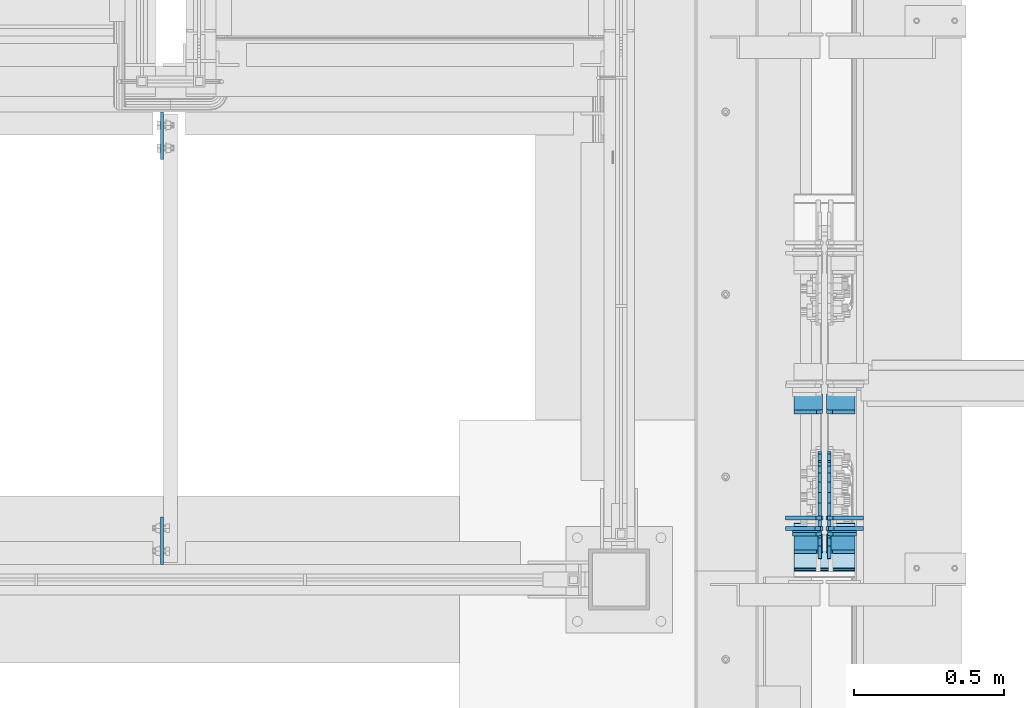
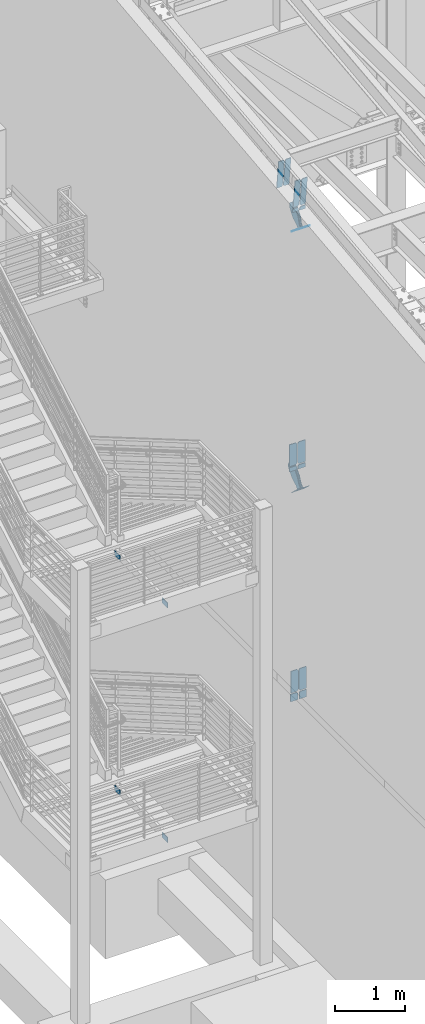
# One storey, part 1023 of 1179: 24 plates, 13 elements without a shape of their own.
"""IFC2X3 building model written with IfcOpenShell, lengths in millimetres."""

import ifcopenshell
import ifcopenshell.guid

model = None  # the IFC model being written
_history = None  # IfcOwnerHistory: only IFC2X3 demands one
_inside = {}  # id of a spatial element -> (the spatial element, [elements in it])
_under = {}  # id of a project, library or spatial element -> (it, [spatial elements below it])
_declared = {}  # id of a project -> (the project, [libraries it declares])
_typed = {}  # id of a type object -> (the type object, [elements of that type])
_made_of = {}  # id of a material, layer set ... -> (it, [elements and type objects made of it])


def new_model(schema):
    """Start an empty IFC model of exactly this schema.

    Asked for "IFC4X3", IfcOpenShell would pick the latest addendum, in which some entities
    have other attributes; the version numbers below select the first issue.
    IFC2X3 requires an IfcOwnerHistory on every rooted entity: one is made here for all.
    """
    global model, _history
    if schema == "IFC4X3":
        model = ifcopenshell.file(schema_version=(4, 3, 0, 0))
    else:
        model = ifcopenshell.file(schema=schema)
    _inside.clear()
    _under.clear()
    _declared.clear()
    _typed.clear()
    _made_of.clear()
    _history = None
    if model.schema == "IFC2X3":
        org = make("IfcOrganization", Name="unknown")
        user = make(
            "IfcPersonAndOrganization",
            ThePerson=make("IfcPerson", FamilyName="unknown"),
            TheOrganization=org,
        )
        app = make(
            "IfcApplication",
            ApplicationDeveloper=org,
            Version="unknown",
            ApplicationFullName="unknown",
            ApplicationIdentifier="unknown",
        )
        _history = make(
            "IfcOwnerHistory",
            OwningUser=user,
            OwningApplication=app,
            ChangeAction="ADDED",
            CreationDate=0,
        )
    return model


def make(cls, **values):
    """One entity of the class cls with the attributes given. An attribute that is None is left unset."""
    return model.create_entity(
        cls, **{name: value for name, value in values.items() if value is not None}
    )


def rooted(cls, **values):
    """An entity with a GlobalId (a new one), such as an element, a storey or a relation."""
    return make(cls, GlobalId=ifcopenshell.guid.new(), OwnerHistory=_history, **values)


def si_unit(unit_type, name, prefix=None):
    """IfcSIUnit, for example si_unit("LENGTHUNIT", "METRE", prefix="MILLI")."""
    return make("IfcSIUnit", UnitType=unit_type, Prefix=prefix, Name=name)


def assignment(units):
    """IfcUnitAssignment: the units of a project."""
    return None if units is None else make("IfcUnitAssignment", Units=units)


def point(xyz):
    """IfcCartesianPoint."""
    return None if xyz is None else make("IfcCartesianPoint", Coordinates=xyz)


def direction(xyz):
    """IfcDirection."""
    return None if xyz is None else make("IfcDirection", DirectionRatios=xyz)


def frame(location, z_axis=None, x_axis=None):
    """IfcAxis2Placement3D, a coordinate frame: its origin and axes. An axis left out is left unset."""
    return make(
        "IfcAxis2Placement3D",
        Location=point(location),
        Axis=direction(z_axis),
        RefDirection=direction(x_axis),
    )


def origin_with_axes():
    """The frame at (0, 0, 0) with the z axis (0, 0, 1) and the x axis (1, 0, 0) written out."""
    return frame((0.0, 0.0, 0.0), z_axis=(0.0, 0.0, 1.0), x_axis=(1.0, 0.0, 0.0))


def place(relative_to, where):
    """IfcLocalPlacement: puts the frame where relative to a parent placement (None: the world)."""
    return make(
        "IfcLocalPlacement", PlacementRelTo=relative_to, RelativePlacement=where
    )


def context(
    kind, dimensions, precision=None, world=None, true_north=None, identifier=None
):
    """IfcGeometricRepresentationContext, for example the 3D "Model" context."""
    return make(
        "IfcGeometricRepresentationContext",
        ContextIdentifier=identifier,
        ContextType=kind,
        CoordinateSpaceDimension=dimensions,
        Precision=precision,
        WorldCoordinateSystem=world,
        TrueNorth=true_north,
    )


def subcontext(parent, identifier, kind, view, scale=None):
    """IfcGeometricRepresentationSubContext, for example "Body" below "Model"."""
    return make(
        "IfcGeometricRepresentationSubContext",
        ContextIdentifier=identifier,
        ContextType=kind,
        ParentContext=parent,
        TargetScale=scale,
        TargetView=view,
    )


def project(units=None, contexts=None):
    """IfcProject with its units and contexts."""
    return rooted(
        "IfcProject",
        Name="project",
        RepresentationContexts=contexts,
        UnitsInContext=assignment(units),
    )


def spatial(cls, under=None, at=None, **own):
    """A site, building, storey or space (cls), placed at a placement, below another one or the project."""
    s = rooted(cls, ObjectPlacement=at, **own)
    if under is not None:
        _under.setdefault(under.id(), (under, []))[1].append(s)
    return s


def faces_of(points, faces, orient=None, outer=None):
    """IfcFace entities. A face is a list of loops; a loop is a list of indices into points, from 0.

    orient and outer hold one flag for each loop. By default every Orientation is true, the
    first loop of a face is its IfcFaceOuterBound and the others are IfcFaceBound.
    """
    made = []
    for i, loops in enumerate(faces):
        bounds = []
        for j, loop in enumerate(loops):
            is_outer = j == 0 if outer is None else outer[i][j]
            bounds.append(
                make(
                    "IfcFaceOuterBound" if is_outer else "IfcFaceBound",
                    Bound=make("IfcPolyLoop", Polygon=[points[k] for k in loop]),
                    Orientation=True if orient is None else orient[i][j],
                )
            )
        made.append(make("IfcFace", Bounds=bounds))
    return made


def faceted_brep(points, faces, orient=None, outer=None, voids=None):
    """IfcFacetedBrep: a solid bounded by flat faces; with voids (closed shells), ...WithVoids."""
    shared = [point(p) for p in points]
    hull = make("IfcClosedShell", CfsFaces=faces_of(shared, faces, orient, outer))
    if voids is None:
        return make("IfcFacetedBrep", Outer=hull)
    return make(
        "IfcFacetedBrepWithVoids",
        Outer=hull,
        Voids=[
            make(cls, CfsFaces=faces_of(shared, fs, o, b)) for cls, fs, o, b in voids
        ],
    )


def shape(context_of_items, identifier, shape_type, items):
    """IfcShapeRepresentation: the items that make up one representation, for example the "Body"."""
    return make(
        "IfcShapeRepresentation",
        ContextOfItems=context_of_items,
        RepresentationIdentifier=identifier,
        RepresentationType=shape_type,
        Items=items,
    )


def material(Name=None, Category=None):
    """IfcMaterial."""
    return make("IfcMaterial", Name=Name, Category=Category)


def made_of(thing, what):
    """Note that an element or type object is made of a material, layer set ...; save() writes the relation."""
    if what is not None:
        _made_of.setdefault(what.id(), (what, []))[1].append(thing)
    return thing


def type_object(cls, material=None, **own):
    """A type object (cls), such as IfcWallType, which elements share."""
    return made_of(rooted(cls, **own), material)


def element(
    cls,
    number,
    at=None,
    inside=None,
    cuts=None,
    type_object=None,
    material=None,
    context=None,
    identifier="Body",
    shape_type=None,
    held_by="IfcProductDefinitionShape",
    body=None,
    shapes=None,
    **own,
):
    """One element of the class cls, such as IfcWall. Its Tag is "e" and its number.

    at: its placement. inside: the storey or other place that contains it. cuts: it is an
    opening in that element (IfcRelVoidsElement). A single representation is given by context,
    identifier, shape_type and body (its items); several are given by shapes. held_by: the class
    of the entity that holds the representations. save() writes the other relations.
    """
    e = rooted(cls, Tag="e%d" % number, ObjectPlacement=at, **own)
    if body is not None:
        shapes = [shape(context, identifier, shape_type, body)]
    if shapes is not None:
        e.Representation = make(held_by, Representations=shapes)
    if inside is not None:
        _inside.setdefault(inside.id(), (inside, []))[1].append(e)
    if cuts is not None:
        rooted(
            "IfcRelVoidsElement", RelatingBuildingElement=cuts, RelatedOpeningElement=e
        )
    if type_object is not None:
        _typed.setdefault(type_object.id(), (type_object, []))[1].append(e)
    return made_of(e, material)


def aggregate(whole, parts):
    """IfcRelAggregates: a whole, such as a stair, and the parts it consists of."""
    return rooted("IfcRelAggregates", RelatingObject=whole, RelatedObjects=parts)


def save(model, path):
    """Write the relations noted so far, then the file.

    IfcRelAggregates (storeys below a building ...), IfcRelContainedInSpatialStructure (elements
    in a storey), IfcRelDefinesByType, IfcRelAssociatesMaterial and IfcRelDeclares: one each for
    every whole, place, type object, material and project.
    """
    for whole, parts in _under.values():
        aggregate(whole, parts)
    for where, things in _inside.values():
        rooted(
            "IfcRelContainedInSpatialStructure",
            RelatedElements=things,
            RelatingStructure=where,
        )
    for kind, things in _typed.values():
        rooted("IfcRelDefinesByType", RelatedObjects=things, RelatingType=kind)
    for what, things in _made_of.values():
        rooted("IfcRelAssociatesMaterial", RelatedObjects=things, RelatingMaterial=what)
    for by, libraries in _declared.values():
        rooted("IfcRelDeclares", RelatingContext=by, RelatedDefinitions=libraries)
    model.write(path)


model = new_model("IFC2X3")

# Units and contexts
model_context = context("Model", 3, precision=1e-05, world=origin_with_axes())
body_context = subcontext(model_context, "Body", "Model", "MODEL_VIEW")
ifc_project = project(units=[si_unit("LENGTHUNIT", "METRE", prefix="MILLI"), si_unit("AREAUNIT", "SQUARE_METRE"), si_unit("VOLUMEUNIT", "CUBIC_METRE"), si_unit("MASSUNIT", "GRAM", prefix="KILO"), si_unit("TIMEUNIT", "SECOND"), si_unit("PLANEANGLEUNIT", "RADIAN"), si_unit("SOLIDANGLEUNIT", "STERADIAN"), si_unit("THERMODYNAMICTEMPERATUREUNIT", "DEGREE_CELSIUS"), si_unit("LUMINOUSINTENSITYUNIT", "LUMEN")], contexts=[model_context])

# Site, building, storey
site_placement = place(None, origin_with_axes())
site = spatial("IfcSite", under=ifc_project, at=site_placement, CompositionType="ELEMENT")
building_placement = place(site_placement, origin_with_axes())
building = spatial("IfcBuilding", under=site, at=building_placement, Name="Undefined", CompositionType="ELEMENT")
storey_placement = place(building_placement, origin_with_axes())
storey = spatial("IfcBuildingStorey", under=building, at=storey_placement, Name="Undefined", CompositionType="ELEMENT", Elevation=0.0)

# Assembly, plate
assembly_1_placement = place(storey_placement, origin_with_axes())
assembly_1 = element("IfcElementAssembly", 1, at=assembly_1_placement, inside=storey, Name="BEAM", AssemblyPlace="NOTDEFINED", PredefinedType="RIGID_FRAME")
ifc_material_1 = material(Name="STEEL/A36")
plate_type_1 = type_object("IfcPlateType", PredefinedType="NOTDEFINED")
plate_1_placement = place(assembly_1_placement, frame((-1781.175, 31635.7, 1997.075), z_axis=(0.0, -1.0, 0.0), x_axis=(0.0, 0.0, -1.0)))
plate_1 = element("IfcPlate", 2, at=plate_1_placement, type_object=plate_type_1, material=ifc_material_1, Name="PLATE", context=body_context, shape_type="Brep", body=[
    faceted_brep([(0.0, -4.76249999999709, 0.0), (0.0, -4.76250000000005, 158.75), (0.0, 4.76250000000005, 158.75), (0.0, 4.76249999999709, 0.0), (88.8999999999996, -4.76250000000005, 158.75), (88.8999999999996, 4.76250000000005, 158.75), (88.8999999999996, -4.76250000000005, 0.0), (88.8999999999996, 4.76250000000005, 0.0)], [[[0, 1, 2, 3]], [[1, 4, 5, 2]], [[4, 6, 7, 5]], [[6, 0, 3, 7]], [[5, 7, 3, 2]], [[6, 4, 1, 0]]]),
])
aggregate(assembly_1, [plate_1])

assembly_2_placement = place(storey_placement, origin_with_axes())
assembly_2 = element("IfcElementAssembly", 3, at=assembly_2_placement, inside=storey, Name="BEAM", AssemblyPlace="NOTDEFINED", PredefinedType="RIGID_FRAME")
plate_2_placement = place(assembly_2_placement, frame((-1781.175, 31635.7, 6070.6), z_axis=(0.0, -1.0, 0.0), x_axis=(0.0, 0.0, -1.0)))
plate_2 = element("IfcPlate", 4, at=plate_2_placement, type_object=plate_type_1, material=ifc_material_1, Name="PLATE", context=body_context, shape_type="Brep", body=[
    faceted_brep([(0.0, -4.76249999999709, 0.0), (0.0, -4.76250000000005, 158.75), (0.0, 4.76250000000005, 158.75), (0.0, 4.76249999999709, 0.0), (88.8999999999996, -4.76250000000005, 158.75), (88.8999999999996, 4.76250000000005, 158.75), (88.8999999999996, -4.76250000000005, 0.0), (88.8999999999996, 4.76250000000005, 0.0)], [[[0, 1, 2, 3]], [[1, 4, 5, 2]], [[4, 6, 7, 5]], [[6, 0, 3, 7]], [[5, 7, 3, 2]], [[6, 4, 1, 0]]]),
])
aggregate(assembly_2, [plate_2])

assembly_3_placement = place(storey_placement, origin_with_axes())
assembly_3 = element("IfcElementAssembly", 5, at=assembly_3_placement, inside=storey, Name="BEAM", AssemblyPlace="NOTDEFINED", PredefinedType="RIGID_FRAME")
plate_3_placement = place(assembly_3_placement, frame((-1781.175, 30124.4, 6070.6), z_axis=(0.0, 1.0, 0.0), x_axis=(0.0, 0.0, -1.0)))
plate_3 = element("IfcPlate", 6, at=plate_3_placement, type_object=plate_type_1, material=ifc_material_1, Name="PLATE", context=body_context, shape_type="Brep", body=[
    faceted_brep([(0.0, -4.76249999999709, 0.0), (0.0, -4.76250000000005, 158.75), (0.0, 4.76250000000005, 158.75), (0.0, 4.76249999999709, 0.0), (88.8999999999996, -4.76250000000005, 158.75), (88.8999999999996, 4.76250000000005, 158.75), (88.8999999999996, -4.76250000000005, 0.0), (88.8999999999996, 4.76250000000005, 0.0)], [[[0, 1, 2, 3]], [[1, 4, 5, 2]], [[4, 6, 7, 5]], [[6, 0, 3, 7]], [[5, 7, 3, 2]], [[6, 4, 1, 0]]]),
])
aggregate(assembly_3, [plate_3])

assembly_4_placement = place(storey_placement, origin_with_axes())
assembly_4 = element("IfcElementAssembly", 7, at=assembly_4_placement, inside=storey, Name="BEAM", AssemblyPlace="NOTDEFINED", PredefinedType="RIGID_FRAME")
plate_4_placement = place(assembly_4_placement, frame((-1781.175, 30124.4, 1997.075), z_axis=(0.0, 1.0, 0.0), x_axis=(0.0, 0.0, -1.0)))
plate_4 = element("IfcPlate", 8, at=plate_4_placement, type_object=plate_type_1, material=ifc_material_1, Name="PLATE", context=body_context, shape_type="Brep", body=[
    faceted_brep([(0.0, -4.76249999999709, 0.0), (0.0, -4.76250000000005, 158.75), (0.0, 4.76250000000005, 158.75), (0.0, 4.76249999999709, 0.0), (88.8999999999996, -4.76250000000005, 158.75), (88.8999999999996, 4.76250000000005, 158.75), (88.8999999999996, -4.76250000000005, 0.0), (88.8999999999996, 4.76250000000005, 0.0)], [[[0, 1, 2, 3]], [[1, 4, 5, 2]], [[4, 6, 7, 5]], [[6, 0, 3, 7]], [[5, 7, 3, 2]], [[6, 4, 1, 0]]]),
])
aggregate(assembly_4, [plate_4])

# Assembly, plates
assembly_5_placement = place(storey_placement, origin_with_axes())
assembly_5 = element("IfcElementAssembly", 9, at=assembly_5_placement, inside=storey, Name="BEAM", AssemblyPlace="NOTDEFINED", PredefinedType="RIGID_FRAME")
ifc_material_2 = material(Name="STEEL/A572-GR.50")
plate_type_2 = type_object("IfcPlateType", PredefinedType="NOTDEFINED")
plate_5_placement = place(assembly_5_placement, frame((534.193750000002, 30689.0189603065, 12187.4895843678), z_axis=(0.0, -0.112284087038017, 0.993676146336441), x_axis=(-1.0, 0.0, 0.0)))
plate_5 = element("IfcPlate", 10, at=plate_5_placement, type_object=plate_type_2, material=ifc_material_2, Name="PLATE", context=body_context, shape_type="Brep", body=[
    faceted_brep([(0.0, -6.34999999999854, 0.0), (0.0, -6.35000000019863, 498.474999998592), (0.0, 6.34999999979118, 498.474999998596), (0.0, 6.34999999999854, 0.0), (76.2000007629395, -6.35000000019863, 498.474999998592), (76.2000007629395, 6.34999999979118, 498.474999998596), (95.25, -6.350000000195, 479.425000761541), (95.25, 6.34999999980209, 479.425000761548), (95.25, -6.35000000000946, 19.0499992370496), (95.25, 6.34999999998399, 19.0499992370533), (76.2000007629395, -6.35000000000218, 0.0), (76.2000007629395, 6.34999999999491, 3.63797880709171e-12)], [[[0, 1, 2, 3]], [[1, 4, 5, 2]], [[4, 6, 7, 5]], [[6, 8, 9, 7]], [[8, 10, 11, 9]], [[10, 0, 3, 11]], [[5, 7, 9, 11, 3, 2]], [[10, 8, 6, 4, 1, 0]]]),
])
plate_6_placement = place(assembly_5_placement, frame((424.656250000002, 30689.0189603065, 12187.4895843678), z_axis=(0.0, -0.112284087038017, 0.993676146336441), x_axis=(-1.0, 0.0, 0.0)))
plate_6 = element("IfcPlate", 11, at=plate_6_placement, type_object=plate_type_2, material=ifc_material_2, Name="PLATE", context=body_context, shape_type="Brep", body=[
    faceted_brep([(0.0, -6.35000000000036, 19.0499999999993), (0.0, -6.350000000195, 479.425000761541), (0.0, 6.34999999980209, 479.425000761548), (0.0, 6.35000000000036, 19.0499999999993), (19.0499992370605, -6.35000000019863, 498.474999998592), (19.0499992370605, 6.34999999979118, 498.474999998596), (95.25, -6.349999999793, 498.474999998598), (95.25, 6.35000000020045, 498.474999998592), (95.25, -6.34999999999309, 1.81898940354586e-12), (95.25, 6.34999999999854, -1.81898940354586e-12), (19.0500000000002, -6.35000000000036, 0.0), (19.0500000000002, 6.35000000000036, 0.0)], [[[0, 1, 2, 3]], [[1, 4, 5, 2]], [[4, 6, 7, 5]], [[6, 8, 9, 7]], [[8, 10, 11, 9]], [[3, 11, 10, 0]], [[5, 7, 9, 11, 3, 2]], [[10, 8, 6, 4, 1, 0]]]),
])
plate_7_placement = place(assembly_5_placement, frame((534.193750000002, 30222.4134704941, 12134.7637826834), z_axis=(0.0, -0.112284087038017, 0.993676146336441), x_axis=(-1.0, 0.0, 0.0)))
plate_7 = element("IfcPlate", 12, at=plate_7_placement, type_object=plate_type_2, material=ifc_material_2, Name="PLATE", context=body_context, shape_type="Brep", body=[
    faceted_brep([(0.0, -6.34999999999854, 0.0), (0.0, -6.35000000019863, 498.474999998592), (0.0, 6.34999999979118, 498.474999998596), (0.0, 6.34999999999854, 0.0), (76.2000007629395, -6.35000000019863, 498.474999998592), (76.2000007629395, 6.34999999979118, 498.474999998596), (95.25, -6.350000000195, 479.425000761541), (95.25, 6.34999999980209, 479.425000761548), (95.25, -6.35000000000946, 19.0499992370496), (95.25, 6.34999999998399, 19.0499992370533), (76.2000007629395, -6.35000000000218, 0.0), (76.2000007629395, 6.34999999999491, 3.63797880709171e-12)], [[[0, 1, 2, 3]], [[1, 4, 5, 2]], [[4, 6, 7, 5]], [[6, 8, 9, 7]], [[8, 10, 11, 9]], [[10, 0, 3, 11]], [[5, 7, 9, 11, 3, 2]], [[10, 8, 6, 4, 1, 0]]]),
])
plate_8_placement = place(assembly_5_placement, frame((424.656250000002, 30222.4134704941, 12134.7637826834), z_axis=(0.0, -0.112284087038017, 0.993676146336441), x_axis=(-1.0, 0.0, 0.0)))
plate_8 = element("IfcPlate", 13, at=plate_8_placement, type_object=plate_type_2, material=ifc_material_2, Name="PLATE", context=body_context, shape_type="Brep", body=[
    faceted_brep([(0.0, -6.35000000000036, 19.0499999999993), (0.0, -6.350000000195, 479.425000761541), (0.0, 6.34999999980209, 479.425000761548), (0.0, 6.35000000000036, 19.0499999999993), (19.0499992370605, -6.35000000019863, 498.474999998592), (19.0499992370605, 6.34999999979118, 498.474999998596), (95.25, -6.349999999793, 498.474999998598), (95.25, 6.35000000020045, 498.474999998592), (95.25, -6.34999999999309, 1.81898940354586e-12), (95.25, 6.34999999999854, -1.81898940354586e-12), (19.0500000000002, -6.35000000000036, 0.0), (19.0500000000002, 6.35000000000036, 0.0)], [[[0, 1, 2, 3]], [[1, 4, 5, 2]], [[4, 6, 7, 5]], [[6, 8, 9, 7]], [[8, 10, 11, 9]], [[3, 11, 10, 0]], [[5, 7, 9, 11, 3, 2]], [[10, 8, 6, 4, 1, 0]]]),
])

assembly_6_placement = place(storey_placement, origin_with_axes())
assembly_6 = element("IfcElementAssembly", 14, at=assembly_6_placement, inside=storey, Name="BEAM", AssemblyPlace="NOTDEFINED", PredefinedType="RIGID_FRAME")
plate_type_3 = type_object("IfcPlateType", PredefinedType="NOTDEFINED")
plate_9_placement = place(assembly_6_placement, frame((558.006250000002, 30244.1470435544, 3703.6375), z_axis=(0.0, 0.0, 1.0), x_axis=(-1.0, 0.0, 0.0)))
plate_9 = element("IfcPlate", 15, at=plate_9_placement, type_object=plate_type_3, material=ifc_material_2, Name="PLATE", context=body_context, shape_type="Brep", body=[
    faceted_brep([(0.0, -6.34999999999854, 0.0), (0.0, -6.35000000000036, 377.825012207031), (0.0, 6.35000000000036, 377.825012207031), (0.0, 6.34999999999854, 0.0), (98.4250011444092, -6.35000000000036, 377.825012207031), (98.4250011444092, 6.35000000000036, 377.825012207031), (120.650001525879, -6.35000000000036, 355.600011825562), (120.650001525879, 6.35000000000036, 355.600011825562), (120.650001525879, -6.35000000000036, 22.2250003814697), (120.650001525879, 6.35000000000036, 22.2250003814697), (98.4250011444092, -6.35000000000036, 0.0), (98.4250011444092, 6.35000000000036, 0.0)], [[[0, 1, 2, 3]], [[1, 4, 5, 2]], [[4, 6, 7, 5]], [[6, 8, 9, 7]], [[8, 10, 11, 9]], [[10, 0, 3, 11]], [[5, 7, 9, 11, 3, 2]], [[10, 8, 6, 4, 1, 0]]]),
])
plate_10_placement = place(assembly_6_placement, frame((426.243750000002, 30244.1470435544, 3703.6375), z_axis=(0.0, 0.0, 1.0), x_axis=(-1.0, 0.0, 0.0)))
plate_10 = element("IfcPlate", 16, at=plate_10_placement, type_object=plate_type_3, material=ifc_material_2, Name="PLATE", context=body_context, shape_type="Brep", body=[
    faceted_brep([(0.0, -6.34999999999854, 22.2250003814697), (0.0, -6.34999999999854, 355.600011825562), (0.0, 6.34999999999854, 355.600011825562), (0.0, 6.34999999999854, 22.2250003814697), (22.2250003814697, -6.34999999999854, 377.825012207031), (22.2250003814697, 6.34999999999854, 377.825012207031), (120.650001525879, -6.34999999999854, 377.825012207031), (120.650001525879, 6.34999999999854, 377.825012207031), (120.650001525879, -6.34999999999854, 0.0), (120.650001525879, 6.34999999999854, 0.0), (22.2250003814697, -6.34999999999854, 0.0), (22.2250003814697, 6.34999999999854, 0.0)], [[[0, 1, 2, 3]], [[1, 4, 5, 2]], [[4, 6, 7, 5]], [[6, 8, 9, 7]], [[8, 10, 11, 9]], [[10, 0, 3, 11]], [[5, 7, 9, 11, 3, 2]], [[10, 8, 6, 4, 1, 0]]]),
])

# Assembly, plate
assembly_7_placement = place(storey_placement, origin_with_axes())
assembly_7 = element("IfcElementAssembly", 17, at=assembly_7_placement, inside=storey, AssemblyPlace="NOTDEFINED", PredefinedType="RIGID_FRAME")
plate_type_4 = type_object("IfcPlateType", PredefinedType="NOTDEFINED")
plate_11_placement = place(assembly_7_placement, frame((415.925000000002, 30215.3602857066, 11728.8505438446), z_axis=(0.0, -0.784152810390106, 0.620567780308725), x_axis=(0.0, 0.620567780308726, 0.784152810390106)))
plate_11 = element("IfcPlate", 18, at=plate_11_placement, type_object=plate_type_4, material=ifc_material_1, context=body_context, shape_type="Brep", body=[
    faceted_brep([(0.0, -6.34999999999854, 0.0), (-8.18545231595635e-11, -6.34999999999854, 91.5986124346418), (-8.18545231595635e-11, 6.34999999999854, 91.5986124346418), (0.0, 6.34999999999854, 0.0), (67.3100000000013, -6.35000000000002, 91.5986124352912), (67.3100000000013, 6.35000000000002, 91.5986124352912), (168.909999999782, -6.35000000000002, 136.286806218), (168.909999999782, 6.35000000000002, 136.286806218), (313.994985846162, -6.35000000000002, 136.286806217971), (313.994985846162, 6.35000000000002, 136.286806217971), (348.623054100175, -6.35000000000002, 129.398855183776), (348.623054100175, 6.35000000000002, 129.398855183776), (377.979312866712, -6.35000000000002, 109.783630186734), (377.979312866712, 6.35000000000002, 109.783630186734), (397.594537863708, -6.35000000000002, 80.4273714201881), (397.594537863708, 6.35000000000002, 80.4273714201881), (404.482488897822, -6.35000000000002, 45.7993092687429), (404.482488897822, 6.35000000000002, 45.7993092687429), (397.594537863562, -6.35000000000002, 11.1712410148175), (397.594537863562, 6.35000000000002, 11.1712410148175), (377.979312866471, -6.35000000000002, -18.1850177516571), (377.979312866471, 6.35000000000002, -18.1850177516571), (348.623054099906, -6.35000000000002, -37.800242748639), (348.623054099906, 6.35000000000002, -37.800242748639), (313.994988897899, -6.35000000000002, -44.6881937828002), (313.994988897899, 6.35000000000002, -44.6881937828002), (168.909999999352, -6.35000000000002, -44.6881937827711), (168.909999999352, 6.35000000000002, -44.6881937827711), (67.309999999783, -6.35000000000002, -1.09139364212751e-11), (67.309999999783, 6.35000000000002, -1.09139364212751e-11)], [[[0, 1, 2, 3]], [[1, 4, 5, 2]], [[4, 6, 7, 5]], [[6, 8, 9, 7]], [[8, 10, 11, 9]], [[10, 12, 13, 11]], [[12, 14, 15, 13]], [[14, 16, 17, 15]], [[16, 18, 19, 17]], [[18, 20, 21, 19]], [[20, 22, 23, 21]], [[22, 24, 25, 23]], [[24, 26, 27, 25]], [[26, 28, 29, 27]], [[28, 0, 3, 29]], [[5, 7, 9, 11, 13, 15, 17, 19, 21, 23, 25, 27, 29, 3, 2]], [[28, 26, 24, 22, 20, 18, 16, 14, 12, 10, 8, 6, 4, 1, 0]]]),
])
aggregate(assembly_7, [plate_11])

assembly_8_placement = place(storey_placement, origin_with_axes())
assembly_8 = element("IfcElementAssembly", 19, at=assembly_8_placement, inside=storey, AssemblyPlace="NOTDEFINED", PredefinedType="RIGID_FRAME")
plate_12_placement = place(assembly_8_placement, frame((447.675000000002, 30215.3602857066, 11728.8505438446), z_axis=(0.0, -0.784152810390106, 0.620567780308725), x_axis=(0.0, 0.620567780308726, 0.784152810390106)))
plate_12 = element("IfcPlate", 20, at=plate_12_placement, type_object=plate_type_4, material=ifc_material_1, context=body_context, shape_type="Brep", body=[
    faceted_brep([(0.0, -6.34999999999854, 0.0), (-8.18545231595635e-11, -6.34999999999854, 91.5986124346418), (-8.18545231595635e-11, 6.34999999999854, 91.5986124346418), (0.0, 6.34999999999854, 0.0), (67.3100000000013, -6.35000000000002, 91.5986124352912), (67.3100000000013, 6.35000000000002, 91.5986124352912), (168.909999999782, -6.35000000000002, 136.286806218), (168.909999999782, 6.35000000000002, 136.286806218), (313.994985846162, -6.35000000000002, 136.286806217971), (313.994985846162, 6.35000000000002, 136.286806217971), (348.623054100175, -6.35000000000002, 129.398855183776), (348.623054100175, 6.35000000000002, 129.398855183776), (377.979312866712, -6.35000000000002, 109.783630186734), (377.979312866712, 6.35000000000002, 109.783630186734), (397.594537863708, -6.35000000000002, 80.4273714201881), (397.594537863708, 6.35000000000002, 80.4273714201881), (404.482488897822, -6.35000000000002, 45.7993092687429), (404.482488897822, 6.35000000000002, 45.7993092687429), (397.594537863562, -6.35000000000002, 11.1712410148175), (397.594537863562, 6.35000000000002, 11.1712410148175), (377.979312866471, -6.35000000000002, -18.1850177516571), (377.979312866471, 6.35000000000002, -18.1850177516571), (348.623054099906, -6.35000000000002, -37.800242748639), (348.623054099906, 6.35000000000002, -37.800242748639), (313.994988897899, -6.35000000000002, -44.6881937828002), (313.994988897899, 6.35000000000002, -44.6881937828002), (168.909999999352, -6.35000000000002, -44.6881937827711), (168.909999999352, 6.35000000000002, -44.6881937827711), (67.309999999783, -6.35000000000002, -1.09139364212751e-11), (67.309999999783, 6.35000000000002, -1.09139364212751e-11)], [[[0, 1, 2, 3]], [[1, 4, 5, 2]], [[4, 6, 7, 5]], [[6, 8, 9, 7]], [[8, 10, 11, 9]], [[10, 12, 13, 11]], [[12, 14, 15, 13]], [[14, 16, 17, 15]], [[16, 18, 19, 17]], [[18, 20, 21, 19]], [[20, 22, 23, 21]], [[22, 24, 25, 23]], [[24, 26, 27, 25]], [[26, 28, 29, 27]], [[28, 0, 3, 29]], [[5, 7, 9, 11, 13, 15, 17, 19, 21, 23, 25, 27, 29, 3, 2]], [[28, 26, 24, 22, 20, 18, 16, 14, 12, 10, 8, 6, 4, 1, 0]]]),
])
aggregate(assembly_8, [plate_12])

assembly_9_placement = place(storey_placement, origin_with_axes())
assembly_9 = element("IfcElementAssembly", 21, at=assembly_9_placement, inside=storey, Name="Plate", AssemblyPlace="NOTDEFINED", PredefinedType="RIGID_FRAME")
plate_type_5 = type_object("IfcPlateType", PredefinedType="NOTDEFINED")
plate_13_placement = place(assembly_9_placement, frame((533.400000000002, 30261.0868592656, 11696.7121163379), z_axis=(0.0, -0.784152810390106, 0.620567780308725), x_axis=(-1.0, 0.0, 0.0)))
plate_13 = element("IfcPlate", 22, at=plate_13_placement, type_object=plate_type_5, material=ifc_material_1, Name="Plate", context=body_context, shape_type="Brep", body=[
    faceted_brep([(0.0, -3.17500000000109, 0.0), (0.0, -3.17500000000291, 203.200000000368), (0.0, 3.17499999998836, 203.200000000361), (0.0, 3.17500000000109, 7.27595761418343e-12), (203.199999999997, -3.17500000000291, 203.200000000368), (203.199999999997, 3.17499999998836, 203.200000000361), (203.199999999997, -3.17499999999927, 3.63797880709171e-12), (203.199999999997, 3.17499999999382, -3.63797880709171e-12)], [[[0, 1, 2, 3]], [[1, 4, 5, 2]], [[4, 6, 7, 5]], [[6, 0, 3, 7]], [[5, 7, 3, 2]], [[6, 4, 1, 0]]]),
])
aggregate(assembly_9, [plate_13])

assembly_10_placement = place(storey_placement, origin_with_axes())
assembly_10 = element("IfcElementAssembly", 23, at=assembly_10_placement, inside=storey, Name="Plate", AssemblyPlace="NOTDEFINED", PredefinedType="RIGID_FRAME")
plate_14_placement = place(assembly_10_placement, frame((533.400000000002, 30258.8835102338, 7162.85000806995), z_axis=(0.0, -0.729241792887682, 0.684256097894611), x_axis=(-1.0, 0.0, 0.0)))
plate_14 = element("IfcPlate", 24, at=plate_14_placement, type_object=plate_type_5, material=ifc_material_1, Name="Plate", context=body_context, shape_type="Brep", body=[
    faceted_brep([(0.0, -3.17500000000109, 0.0), (0.0, -3.17500000000291, 203.200000000368), (0.0, 3.17499999998836, 203.200000000361), (0.0, 3.17500000000109, 7.27595761418343e-12), (203.199999999997, -3.17500000000291, 203.200000000368), (203.199999999997, 3.17499999998836, 203.200000000361), (203.199999999997, -3.17499999999927, 3.63797880709171e-12), (203.199999999997, 3.17499999999382, -3.63797880709171e-12)], [[[0, 1, 2, 3]], [[1, 4, 5, 2]], [[4, 6, 7, 5]], [[6, 0, 3, 7]], [[5, 7, 3, 2]], [[6, 4, 1, 0]]]),
])
aggregate(assembly_10, [plate_14])

# Plate
plate_type_6 = type_object("IfcPlateType", PredefinedType="NOTDEFINED")
plate_15_placement = place(assembly_5_placement, frame((422.275000000001, 30224.9425551523, 12109.4879184263), z_axis=(-1.0, 0.0, 0.0), x_axis=(0.0, 0.112284087038014, -0.993676146336441)))
plate_15 = element("IfcPlate", 25, at=plate_15_placement, type_object=plate_type_6, material=ifc_material_2, Name="PLATE", context=body_context, shape_type="Brep", body=[
    faceted_brep([(0.0, 6.35000000000036, 19.0499999999993), (19.0500000000002, 6.35000000000036, 0.0), (19.0500000000002, -6.35000000000036, 0.0), (0.0, -6.35000000000036, 19.0499999999993), (0.0, -6.35000000000036, 96.8374999999978), (0.0, 6.35000000000036, 96.8374999999978), (67.1710410456399, -6.34999999997308, 96.8375), (67.1710410456326, 6.35000000002037, 96.8375), (67.1710410456399, -6.34999999997308, 0.0), (67.1710410456326, 6.35000000002037, 0.0)], [[[0, 1, 2, 3]], [[4, 5, 0, 3]], [[4, 6, 7, 5]], [[6, 8, 9, 7]], [[9, 8, 2, 1]], [[5, 7, 9, 1, 0]], [[8, 6, 4, 3, 2]]]),
])

plate_16_placement = place(assembly_5_placement, frame((441.325000000001, 30224.9425551523, 12109.4879184263), z_axis=(1.0, 0.0, 0.0), x_axis=(0.0, 0.112284087038014, -0.993676146336441)))
plate_16 = element("IfcPlate", 26, at=plate_16_placement, type_object=plate_type_6, material=ifc_material_2, Name="PLATE", context=body_context, shape_type="Brep", body=[
    faceted_brep([(0.0, 6.35000000000036, 19.0499999999993), (19.0500000000002, 6.35000000000036, 0.0), (19.0500000000002, -6.35000000000036, 0.0), (0.0, -6.35000000000036, 19.0499999999993), (0.0, -6.35000000000036, 96.8374999999978), (0.0, 6.35000000000036, 96.8374999999978), (67.1710410456399, -6.34999999997308, 96.8375), (67.1710410456326, 6.35000000002037, 96.8375), (67.1710410456399, -6.34999999997308, 0.0), (67.1710410456326, 6.35000000002037, 0.0)], [[[0, 1, 2, 3]], [[4, 5, 0, 3]], [[4, 6, 7, 5]], [[6, 8, 9, 7]], [[9, 8, 2, 1]], [[5, 7, 9, 1, 0]], [[8, 6, 4, 3, 2]]]),
])

aggregate(assembly_5, [plate_5, plate_6, plate_7, plate_8, plate_15, plate_16])

# Assembly, plates
assembly_11_placement = place(storey_placement, origin_with_axes())
assembly_11 = element("IfcElementAssembly", 27, at=assembly_11_placement, inside=storey, Name="BEAM", AssemblyPlace="NOTDEFINED", PredefinedType="RIGID_FRAME")
plate_type_7 = type_object("IfcPlateType", PredefinedType="NOTDEFINED")
plate_17_placement = place(assembly_11_placement, frame((422.275, 30278.9504404273, 7594.6), z_axis=(-1.0, 0.0, 0.0), x_axis=(0.0, 0.0, -1.0)))
plate_17 = element("IfcPlate", 28, at=plate_17_placement, type_object=plate_type_7, material=ifc_material_2, Name="PLATE", context=body_context, shape_type="Brep", body=[
    faceted_brep([(0.0, 6.35000000000036, 19.0499999999993), (19.0500000000002, 6.35000000000036, 0.0), (19.0500000000002, -6.35000000000036, 0.0), (0.0, -6.35000000000036, 19.0499999999993), (0.0, -6.34999999999854, 120.650000000001), (0.0, 6.34999999999854, 120.650000000001), (72.5857973213488, -6.34999999999854, 120.65), (72.5857973213488, 6.34999999999854, 120.65), (72.5857973213488, -6.34999999999854, 0.0), (72.5857973213488, 6.34999999999854, 0.0)], [[[0, 1, 2, 3]], [[4, 5, 0, 3]], [[4, 6, 7, 5]], [[6, 8, 9, 7]], [[9, 8, 2, 1]], [[5, 7, 9, 1, 0]], [[8, 6, 4, 3, 2]]]),
])
plate_18_placement = place(assembly_11_placement, frame((441.325, 30278.9504404273, 7594.6), z_axis=(1.0, 0.0, 0.0), x_axis=(0.0, 0.0, -1.0)))
plate_18 = element("IfcPlate", 29, at=plate_18_placement, type_object=plate_type_7, material=ifc_material_2, Name="PLATE", context=body_context, shape_type="Brep", body=[
    faceted_brep([(0.0, 6.35000000000036, 19.0499999999993), (19.0500000000002, 6.35000000000036, 0.0), (19.0500000000002, -6.35000000000036, 0.0), (0.0, -6.35000000000036, 19.0499999999993), (0.0, -6.34999999999854, 120.650000000001), (0.0, 6.34999999999854, 120.650000000001), (72.5857973213488, -6.34999999999854, 120.65), (72.5857973213488, 6.34999999999854, 120.65), (72.5857973213488, -6.34999999999854, 0.0), (72.5857973213488, 6.34999999999854, 0.0)], [[[0, 1, 2, 3]], [[4, 5, 0, 3]], [[4, 6, 7, 5]], [[6, 8, 9, 7]], [[9, 8, 2, 1]], [[5, 7, 9, 1, 0]], [[8, 6, 4, 3, 2]]]),
])
plate_type_8 = type_object("IfcPlateType", PredefinedType="NOTDEFINED")
plate_19_placement = place(assembly_11_placement, frame((426.243750000001, 30278.9504404273, 7615.2375), z_axis=(-1.0, 0.0, 0.0), x_axis=(0.0, 0.0, 1.0)))
plate_19 = element("IfcPlate", 30, at=plate_19_placement, type_object=plate_type_8, material=ifc_material_2, Name="PLATE", context=body_context, shape_type="Brep", body=[
    faceted_brep([(0.0, -6.34999999999854, 22.2250003814697), (0.0, -6.34999999999854, 124.618750000001), (0.0, 6.34999999999854, 124.618750000001), (0.0, 6.34999999999854, 22.2250003814697), (377.825000000001, -6.34999999999854, 124.61875), (377.825000000001, 6.34999999999854, 124.61875), (377.825000000001, -6.34999999999854, 22.2250003814697), (377.825000000001, 6.34999999999854, 22.2250003814697), (355.599999618531, -6.34999999999854, 0.0), (355.599999618531, 6.34999999999854, 0.0), (22.2250003814697, -6.34999999999854, 0.0), (22.2250003814697, 6.34999999999854, 0.0)], [[[0, 1, 2, 3]], [[1, 4, 5, 2]], [[4, 6, 7, 5]], [[6, 8, 9, 7]], [[8, 10, 11, 9]], [[10, 0, 3, 11]], [[5, 7, 9, 11, 3, 2]], [[10, 8, 6, 4, 1, 0]]]),
])
plate_20_placement = place(assembly_11_placement, frame((437.356250000001, 30278.9504404273, 7615.2375), z_axis=(1.0, 0.0, 0.0), x_axis=(0.0, 0.0, 1.0)))
plate_20 = element("IfcPlate", 31, at=plate_20_placement, type_object=plate_type_8, material=ifc_material_2, Name="PLATE", context=body_context, shape_type="Brep", body=[
    faceted_brep([(0.0, -6.34999999999854, 22.2250003814697), (0.0, -6.34999999999854, 124.618750000001), (0.0, 6.34999999999854, 124.618750000001), (0.0, 6.34999999999854, 22.2250003814697), (377.825000000001, -6.34999999999854, 124.61875), (377.825000000001, 6.34999999999854, 124.61875), (377.825000000001, -6.34999999999854, 22.2250003814697), (377.825000000001, 6.34999999999854, 22.2250003814697), (355.599999618531, -6.34999999999854, 0.0), (355.599999618531, 6.34999999999854, 0.0), (22.2250003814697, -6.34999999999854, 0.0), (22.2250003814697, 6.34999999999854, 0.0)], [[[0, 1, 2, 3]], [[1, 4, 5, 2]], [[4, 6, 7, 5]], [[6, 8, 9, 7]], [[8, 10, 11, 9]], [[10, 0, 3, 11]], [[5, 7, 9, 11, 3, 2]], [[10, 8, 6, 4, 1, 0]]]),
])
aggregate(assembly_11, [plate_17, plate_18, plate_19, plate_20])

# Plate
plate_type_9 = type_object("IfcPlateType", PredefinedType="NOTDEFINED")
plate_21_placement = place(assembly_6_placement, frame((419.100000000001, 30244.146981566, 3683.00000010165), z_axis=(-1.0, 0.0, 0.0), x_axis=(0.0, 0.0, -1.0)))
plate_21 = element("IfcPlate", 32, at=plate_21_placement, type_object=plate_type_9, material=ifc_material_2, Name="PLATE", context=body_context, shape_type="Brep", body=[
    faceted_brep([(0.0, -6.35000000000036, 19.0499999999993), (0.0, -6.35000000000036, 117.474999999999), (0.0, 6.35000000000036, 117.474999999999), (0.0, 6.35000000000036, 19.0499999999993), (131.240777340528, -6.34999999982756, 117.475), (131.240777340528, 6.35000000017317, 117.475), (131.240777340528, -6.34999999982756, 0.0), (131.240777340528, 6.35000000017317, 0.0), (19.0500000000002, -6.35000000000036, 0.0), (19.0500000000002, 6.35000000000036, 0.0)], [[[0, 1, 2, 3]], [[1, 4, 5, 2]], [[4, 6, 7, 5]], [[6, 8, 9, 7]], [[3, 9, 8, 0]], [[5, 7, 9, 3, 2]], [[8, 6, 4, 1, 0]]]),
])

plate_22_placement = place(assembly_6_placement, frame((444.500000000001, 30244.146981566, 3683.00000010165), z_axis=(1.0, 0.0, 0.0), x_axis=(0.0, 0.0, -1.0)))
plate_22 = element("IfcPlate", 33, at=plate_22_placement, type_object=plate_type_9, material=ifc_material_2, Name="PLATE", context=body_context, shape_type="Brep", body=[
    faceted_brep([(0.0, -6.35000000000036, 19.0499999999993), (0.0, -6.35000000000036, 117.474999999999), (0.0, 6.35000000000036, 117.474999999999), (0.0, 6.35000000000036, 19.0499999999993), (131.240777340528, -6.34999999982756, 117.475), (131.240777340528, 6.35000000017317, 117.475), (131.240777340528, -6.34999999982756, 0.0), (131.240777340528, 6.35000000017317, 0.0), (19.0500000000002, -6.35000000000036, 0.0), (19.0500000000002, 6.35000000000036, 0.0)], [[[0, 1, 2, 3]], [[1, 4, 5, 2]], [[4, 6, 7, 5]], [[6, 8, 9, 7]], [[3, 9, 8, 0]], [[5, 7, 9, 3, 2]], [[8, 6, 4, 1, 0]]]),
])

aggregate(assembly_6, [plate_21, plate_22, plate_9, plate_10])

# Assembly, plate
assembly_12_placement = place(storey_placement, origin_with_axes())
assembly_12 = element("IfcElementAssembly", 34, at=assembly_12_placement, inside=storey, AssemblyPlace="NOTDEFINED", PredefinedType="RIGID_FRAME")
plate_type_10 = type_object("IfcPlateType", PredefinedType="NOTDEFINED")
plate_23_placement = place(assembly_12_placement, frame((415.925000000002, 30223.5250010037, 7191.67347342564), z_axis=(0.0, -0.729241792887682, 0.684256097894611), x_axis=(0.0, 0.684256097894612, 0.729241792887681)))
plate_23 = element("IfcPlate", 35, at=plate_23_placement, type_object=plate_type_10, material=ifc_material_1, context=body_context, shape_type="Brep", body=[
    faceted_brep([(0.0, -6.34999999999854, 0.0), (-4.35647962149233e-10, -6.34999999999854, 112.184930806416), (-4.35647962149233e-10, 6.34999999999854, 112.184930806416), (0.0, 6.34999999999854, 0.0), (82.5499999996491, -6.34999999999854, 112.184930806461), (82.5499999996491, 6.34999999999854, 112.184930806461), (184.149999999618, -6.34999999999854, 149.75496540347), (184.149999999618, 6.34999999999854, 149.75496540347), (327.919242323534, -6.34999999999854, 149.754965403559), (327.919242323534, 6.34999999999854, 149.754965403559), (363.762328723451, -6.34999999999854, 142.625332233587), (363.762328723451, 6.34999999999854, 142.625332233587), (394.148630137406, -6.34999999999854, 122.321854743475), (394.148630137406, 6.34999999999854, 122.321854743475), (414.452107627645, -6.34999999999854, 91.9355533295929), (414.452107627645, 6.34999999999854, 91.9355533295929), (421.581740797776, -6.34999999999854, 56.0924638777396), (421.581740797776, 6.34999999999854, 56.0924638777396), (414.452107627878, -6.34999999999854, 20.2493774776722), (414.452107627878, 6.34999999999854, 20.2493774776722), (394.14863013775, -6.34999999999854, -10.1369239363994), (394.14863013775, 6.34999999999854, -10.1369239363994), (363.762328723789, -6.34999999999854, -30.4404014266784), (363.762328723789, 6.34999999999854, -30.4404014266784), (327.919240798041, -6.34999999999854, -37.570034596738), (327.919240798041, 6.34999999999854, -37.570034596738), (184.150000000338, -6.34999999999854, -37.5700345968289), (184.150000000338, 6.34999999999854, -37.5700345968289), (82.550000000203, -6.34999999999854, 1.2732925824821e-10), (82.550000000203, 6.34999999999854, 1.2732925824821e-10)], [[[0, 1, 2, 3]], [[1, 4, 5, 2]], [[4, 6, 7, 5]], [[6, 8, 9, 7]], [[8, 10, 11, 9]], [[10, 12, 13, 11]], [[12, 14, 15, 13]], [[14, 16, 17, 15]], [[16, 18, 19, 17]], [[18, 20, 21, 19]], [[20, 22, 23, 21]], [[22, 24, 25, 23]], [[24, 26, 27, 25]], [[26, 28, 29, 27]], [[28, 0, 3, 29]], [[5, 7, 9, 11, 13, 15, 17, 19, 21, 23, 25, 27, 29, 3, 2]], [[28, 26, 24, 22, 20, 18, 16, 14, 12, 10, 8, 6, 4, 1, 0]]]),
])
aggregate(assembly_12, [plate_23])

assembly_13_placement = place(storey_placement, origin_with_axes())
assembly_13 = element("IfcElementAssembly", 36, at=assembly_13_placement, inside=storey, AssemblyPlace="NOTDEFINED", PredefinedType="RIGID_FRAME")
plate_24_placement = place(assembly_13_placement, frame((447.675000000002, 30223.5250010037, 7191.67347342564), z_axis=(0.0, -0.729241792887682, 0.684256097894611), x_axis=(0.0, 0.684256097894612, 0.729241792887681)))
plate_24 = element("IfcPlate", 37, at=plate_24_placement, type_object=plate_type_10, material=ifc_material_1, context=body_context, shape_type="Brep", body=[
    faceted_brep([(0.0, -6.34999999999854, 0.0), (-4.35647962149233e-10, -6.34999999999854, 112.184930806416), (-4.35647962149233e-10, 6.34999999999854, 112.184930806416), (0.0, 6.34999999999854, 0.0), (82.5499999996491, -6.34999999999854, 112.184930806461), (82.5499999996491, 6.34999999999854, 112.184930806461), (184.149999999618, -6.34999999999854, 149.75496540347), (184.149999999618, 6.34999999999854, 149.75496540347), (327.919242323534, -6.34999999999854, 149.754965403559), (327.919242323534, 6.34999999999854, 149.754965403559), (363.762328723451, -6.34999999999854, 142.625332233587), (363.762328723451, 6.34999999999854, 142.625332233587), (394.148630137406, -6.34999999999854, 122.321854743475), (394.148630137406, 6.34999999999854, 122.321854743475), (414.452107627645, -6.34999999999854, 91.9355533295929), (414.452107627645, 6.34999999999854, 91.9355533295929), (421.581740797776, -6.34999999999854, 56.0924638777396), (421.581740797776, 6.34999999999854, 56.0924638777396), (414.452107627878, -6.34999999999854, 20.2493774776722), (414.452107627878, 6.34999999999854, 20.2493774776722), (394.14863013775, -6.34999999999854, -10.1369239363994), (394.14863013775, 6.34999999999854, -10.1369239363994), (363.762328723789, -6.34999999999854, -30.4404014266784), (363.762328723789, 6.34999999999854, -30.4404014266784), (327.919240798041, -6.34999999999854, -37.570034596738), (327.919240798041, 6.34999999999854, -37.570034596738), (184.150000000338, -6.34999999999854, -37.5700345968289), (184.150000000338, 6.34999999999854, -37.5700345968289), (82.550000000203, -6.34999999999854, 1.2732925824821e-10), (82.550000000203, 6.34999999999854, 1.2732925824821e-10)], [[[0, 1, 2, 3]], [[1, 4, 5, 2]], [[4, 6, 7, 5]], [[6, 8, 9, 7]], [[8, 10, 11, 9]], [[10, 12, 13, 11]], [[12, 14, 15, 13]], [[14, 16, 17, 15]], [[16, 18, 19, 17]], [[18, 20, 21, 19]], [[20, 22, 23, 21]], [[22, 24, 25, 23]], [[24, 26, 27, 25]], [[26, 28, 29, 27]], [[28, 0, 3, 29]], [[5, 7, 9, 11, 13, 15, 17, 19, 21, 23, 25, 27, 29, 3, 2]], [[28, 26, 24, 22, 20, 18, 16, 14, 12, 10, 8, 6, 4, 1, 0]]]),
])
aggregate(assembly_13, [plate_24])

save(model, "model.ifc")
